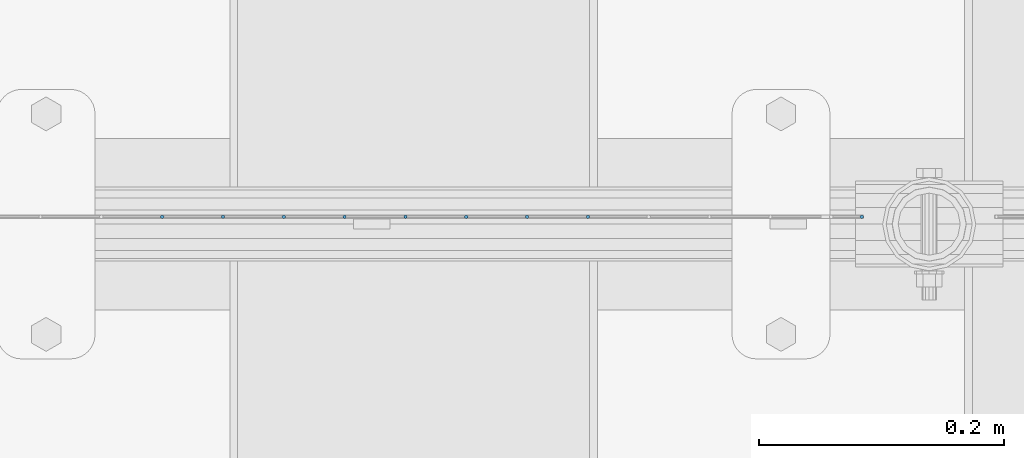
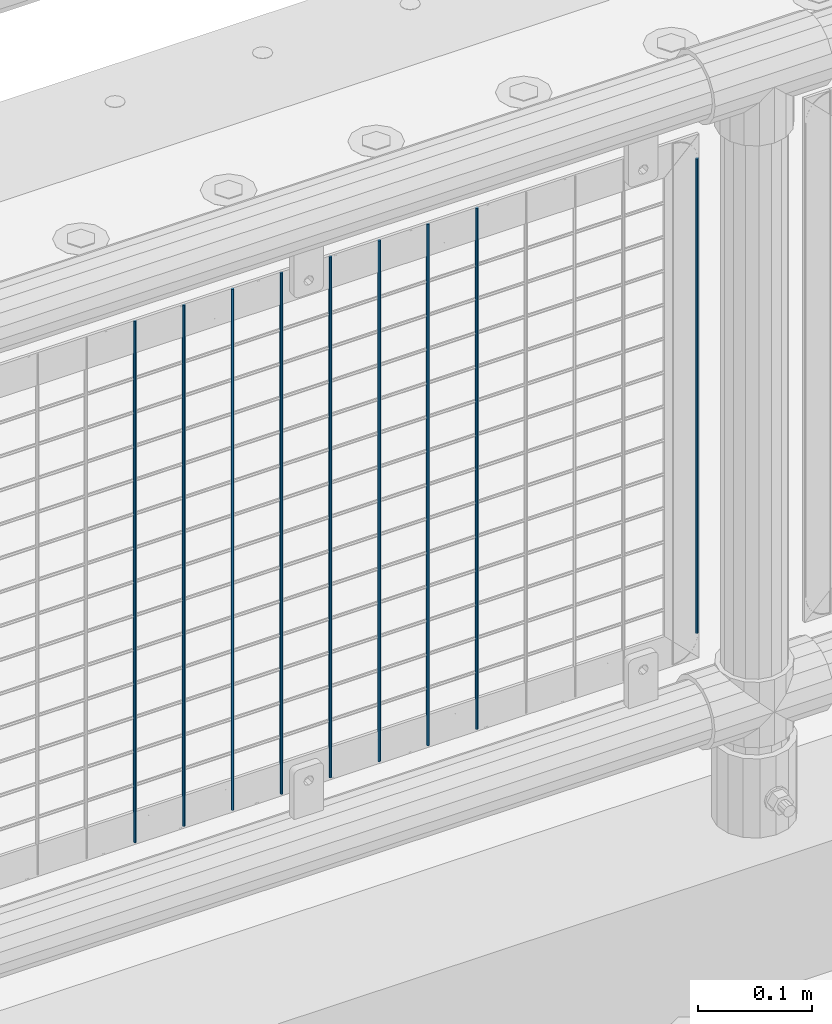
# One storey, part 71 of 208: 9 columns.
"""IFC2X3 building model written with IfcOpenShell, lengths in millimetres."""

import ifcopenshell
import ifcopenshell.guid

model = None  # the IFC model being written
_history = None  # IfcOwnerHistory: only IFC2X3 demands one
_inside = {}  # id of a spatial element -> (the spatial element, [elements in it])
_under = {}  # id of a project, library or spatial element -> (it, [spatial elements below it])
_declared = {}  # id of a project -> (the project, [libraries it declares])
_typed = {}  # id of a type object -> (the type object, [elements of that type])
_made_of = {}  # id of a material, layer set ... -> (it, [elements and type objects made of it])


def new_model(schema):
    """Start an empty IFC model of exactly this schema.

    Asked for "IFC4X3", IfcOpenShell would pick the latest addendum, in which some entities
    have other attributes; the version numbers below select the first issue.
    IFC2X3 requires an IfcOwnerHistory on every rooted entity: one is made here for all.
    """
    global model, _history
    if schema == "IFC4X3":
        model = ifcopenshell.file(schema_version=(4, 3, 0, 0))
    else:
        model = ifcopenshell.file(schema=schema)
    _inside.clear()
    _under.clear()
    _declared.clear()
    _typed.clear()
    _made_of.clear()
    _history = None
    if model.schema == "IFC2X3":
        org = make("IfcOrganization", Name="unknown")
        user = make(
            "IfcPersonAndOrganization",
            ThePerson=make("IfcPerson", FamilyName="unknown"),
            TheOrganization=org,
        )
        app = make(
            "IfcApplication",
            ApplicationDeveloper=org,
            Version="unknown",
            ApplicationFullName="unknown",
            ApplicationIdentifier="unknown",
        )
        _history = make(
            "IfcOwnerHistory",
            OwningUser=user,
            OwningApplication=app,
            ChangeAction="ADDED",
            CreationDate=0,
        )
    return model


def make(cls, **values):
    """One entity of the class cls with the attributes given. An attribute that is None is left unset."""
    return model.create_entity(
        cls, **{name: value for name, value in values.items() if value is not None}
    )


def rooted(cls, **values):
    """An entity with a GlobalId (a new one), such as an element, a storey or a relation."""
    return make(cls, GlobalId=ifcopenshell.guid.new(), OwnerHistory=_history, **values)


def si_unit(unit_type, name, prefix=None):
    """IfcSIUnit, for example si_unit("LENGTHUNIT", "METRE", prefix="MILLI")."""
    return make("IfcSIUnit", UnitType=unit_type, Prefix=prefix, Name=name)


def assignment(units):
    """IfcUnitAssignment: the units of a project."""
    return None if units is None else make("IfcUnitAssignment", Units=units)


def point(xyz):
    """IfcCartesianPoint."""
    return None if xyz is None else make("IfcCartesianPoint", Coordinates=xyz)


def direction(xyz):
    """IfcDirection."""
    return None if xyz is None else make("IfcDirection", DirectionRatios=xyz)


def frame(location, z_axis=None, x_axis=None):
    """IfcAxis2Placement3D, a coordinate frame: its origin and axes. An axis left out is left unset."""
    return make(
        "IfcAxis2Placement3D",
        Location=point(location),
        Axis=direction(z_axis),
        RefDirection=direction(x_axis),
    )


def origin_with_axes():
    """The frame at (0, 0, 0) with the z axis (0, 0, 1) and the x axis (1, 0, 0) written out."""
    return frame((0.0, 0.0, 0.0), z_axis=(0.0, 0.0, 1.0), x_axis=(1.0, 0.0, 0.0))


def place(relative_to, where):
    """IfcLocalPlacement: puts the frame where relative to a parent placement (None: the world)."""
    return make(
        "IfcLocalPlacement", PlacementRelTo=relative_to, RelativePlacement=where
    )


def context(
    kind, dimensions, precision=None, world=None, true_north=None, identifier=None
):
    """IfcGeometricRepresentationContext, for example the 3D "Model" context."""
    return make(
        "IfcGeometricRepresentationContext",
        ContextIdentifier=identifier,
        ContextType=kind,
        CoordinateSpaceDimension=dimensions,
        Precision=precision,
        WorldCoordinateSystem=world,
        TrueNorth=true_north,
    )


def subcontext(parent, identifier, kind, view, scale=None):
    """IfcGeometricRepresentationSubContext, for example "Body" below "Model"."""
    return make(
        "IfcGeometricRepresentationSubContext",
        ContextIdentifier=identifier,
        ContextType=kind,
        ParentContext=parent,
        TargetScale=scale,
        TargetView=view,
    )


def project(units=None, contexts=None):
    """IfcProject with its units and contexts."""
    return rooted(
        "IfcProject",
        Name="project",
        RepresentationContexts=contexts,
        UnitsInContext=assignment(units),
    )


def spatial(cls, under=None, at=None, **own):
    """A site, building, storey or space (cls), placed at a placement, below another one or the project."""
    s = rooted(cls, ObjectPlacement=at, **own)
    if under is not None:
        _under.setdefault(under.id(), (under, []))[1].append(s)
    return s


def faces_of(points, faces, orient=None, outer=None):
    """IfcFace entities. A face is a list of loops; a loop is a list of indices into points, from 0.

    orient and outer hold one flag for each loop. By default every Orientation is true, the
    first loop of a face is its IfcFaceOuterBound and the others are IfcFaceBound.
    """
    made = []
    for i, loops in enumerate(faces):
        bounds = []
        for j, loop in enumerate(loops):
            is_outer = j == 0 if outer is None else outer[i][j]
            bounds.append(
                make(
                    "IfcFaceOuterBound" if is_outer else "IfcFaceBound",
                    Bound=make("IfcPolyLoop", Polygon=[points[k] for k in loop]),
                    Orientation=True if orient is None else orient[i][j],
                )
            )
        made.append(make("IfcFace", Bounds=bounds))
    return made


def faceted_brep(points, faces, orient=None, outer=None, voids=None):
    """IfcFacetedBrep: a solid bounded by flat faces; with voids (closed shells), ...WithVoids."""
    shared = [point(p) for p in points]
    hull = make("IfcClosedShell", CfsFaces=faces_of(shared, faces, orient, outer))
    if voids is None:
        return make("IfcFacetedBrep", Outer=hull)
    return make(
        "IfcFacetedBrepWithVoids",
        Outer=hull,
        Voids=[
            make(cls, CfsFaces=faces_of(shared, fs, o, b)) for cls, fs, o, b in voids
        ],
    )


def shape(context_of_items, identifier, shape_type, items):
    """IfcShapeRepresentation: the items that make up one representation, for example the "Body"."""
    return make(
        "IfcShapeRepresentation",
        ContextOfItems=context_of_items,
        RepresentationIdentifier=identifier,
        RepresentationType=shape_type,
        Items=items,
    )


def material(Name=None, Category=None):
    """IfcMaterial."""
    return make("IfcMaterial", Name=Name, Category=Category)


def made_of(thing, what):
    """Note that an element or type object is made of a material, layer set ...; save() writes the relation."""
    if what is not None:
        _made_of.setdefault(what.id(), (what, []))[1].append(thing)
    return thing


def type_object(cls, material=None, **own):
    """A type object (cls), such as IfcWallType, which elements share."""
    return made_of(rooted(cls, **own), material)


def element(
    cls,
    number,
    at=None,
    inside=None,
    cuts=None,
    type_object=None,
    material=None,
    context=None,
    identifier="Body",
    shape_type=None,
    held_by="IfcProductDefinitionShape",
    body=None,
    shapes=None,
    **own,
):
    """One element of the class cls, such as IfcWall. Its Tag is "e" and its number.

    at: its placement. inside: the storey or other place that contains it. cuts: it is an
    opening in that element (IfcRelVoidsElement). A single representation is given by context,
    identifier, shape_type and body (its items); several are given by shapes. held_by: the class
    of the entity that holds the representations. save() writes the other relations.
    """
    e = rooted(cls, Tag="e%d" % number, ObjectPlacement=at, **own)
    if body is not None:
        shapes = [shape(context, identifier, shape_type, body)]
    if shapes is not None:
        e.Representation = make(held_by, Representations=shapes)
    if inside is not None:
        _inside.setdefault(inside.id(), (inside, []))[1].append(e)
    if cuts is not None:
        rooted(
            "IfcRelVoidsElement", RelatingBuildingElement=cuts, RelatedOpeningElement=e
        )
    if type_object is not None:
        _typed.setdefault(type_object.id(), (type_object, []))[1].append(e)
    return made_of(e, material)


def aggregate(whole, parts):
    """IfcRelAggregates: a whole, such as a stair, and the parts it consists of."""
    return rooted("IfcRelAggregates", RelatingObject=whole, RelatedObjects=parts)


def save(model, path):
    """Write the relations noted so far, then the file.

    IfcRelAggregates (storeys below a building ...), IfcRelContainedInSpatialStructure (elements
    in a storey), IfcRelDefinesByType, IfcRelAssociatesMaterial and IfcRelDeclares: one each for
    every whole, place, type object, material and project.
    """
    for whole, parts in _under.values():
        aggregate(whole, parts)
    for where, things in _inside.values():
        rooted(
            "IfcRelContainedInSpatialStructure",
            RelatedElements=things,
            RelatingStructure=where,
        )
    for kind, things in _typed.values():
        rooted("IfcRelDefinesByType", RelatedObjects=things, RelatingType=kind)
    for what, things in _made_of.values():
        rooted("IfcRelAssociatesMaterial", RelatedObjects=things, RelatingMaterial=what)
    for by, libraries in _declared.values():
        rooted("IfcRelDeclares", RelatingContext=by, RelatedDefinitions=libraries)
    model.write(path)


model = new_model("IFC2X3")

# Units and contexts
model_context = context("Model", 3, precision=1e-05, world=origin_with_axes())
body_context = subcontext(model_context, "Body", "Model", "MODEL_VIEW")
ifc_project = project(units=[si_unit("LENGTHUNIT", "METRE", prefix="MILLI"), si_unit("AREAUNIT", "SQUARE_METRE"), si_unit("VOLUMEUNIT", "CUBIC_METRE"), si_unit("MASSUNIT", "GRAM", prefix="KILO"), si_unit("TIMEUNIT", "SECOND"), si_unit("PLANEANGLEUNIT", "RADIAN"), si_unit("SOLIDANGLEUNIT", "STERADIAN"), si_unit("THERMODYNAMICTEMPERATUREUNIT", "DEGREE_CELSIUS"), si_unit("LUMINOUSINTENSITYUNIT", "LUMEN")], contexts=[model_context])

# Site, building, storey
site_placement = place(None, origin_with_axes())
site = spatial("IfcSite", under=ifc_project, at=site_placement, CompositionType="ELEMENT")
building_placement = place(site_placement, origin_with_axes())
building = spatial("IfcBuilding", under=site, at=building_placement, Name="Standard", CompositionType="ELEMENT")
storey_placement = place(building_placement, origin_with_axes())
storey = spatial("IfcBuildingStorey", under=building, at=storey_placement, Name="Undefined", CompositionType="ELEMENT", Elevation=0.0)

# Columns
ifc_material = material(Name="Misc_Undefined")
column_type = type_object("IfcColumnType", Name="D3", PredefinedType="NOTDEFINED")
for number, where, z_axis, x_axis in (
    (1, (-34107.625, 4670.50000000001, 353.020000000002), (-1.0, 0.0, 0.0), (0.0, 0.0, 1.0)),
    (2, (-34157.28, 4670.50000000001, 353.020000000002), (-1.0, 0.0, 0.0), (0.0, 0.0, 1.0)),
    (3, (-34206.935, 4670.50000000001, 353.020000000002), (-1.0, 0.0, 0.0), (0.0, 0.0, 1.0)),
    (4, (-34256.59, 4670.50000000001, 353.020000000002), (-1.0, 0.0, 0.0), (0.0, 0.0, 1.0)),
    (5, (-34306.245, 4670.50000000001, 353.020000000002), (-1.0, 0.0, 0.0), (0.0, 0.0, 1.0)),
    (6, (-34355.9, 4670.50000000001, 353.020000000002), (-1.0, 0.0, 0.0), (0.0, 0.0, 1.0)),
    (7, (-34405.555, 4670.50000000001, 353.020000000002), (-1.0, 0.0, 0.0), (0.0, 0.0, 1.0)),
    (8, (-34455.21, 4670.5, 353.020000000002), (-1.0, 0.0, 0.0), (0.0, 0.0, 1.0)),
):
    element("IfcColumn", number, at=place(storey_placement, frame(where, z_axis=z_axis, x_axis=x_axis)), inside=storey, type_object=column_type, material=ifc_material, ObjectType="D3", context=body_context, shape_type="Brep", body=[
        faceted_brep([(0.0, -1.49999999999909, 3.63797880709171e-12), (-7.27595761418343e-12, -0.749999999999091, -1.29903810567669), (560.0, -0.75, -1.29903810567703), (560.0, -1.5, 0.0), (-3.63797880709171e-12, 0.750000000000909, -1.29903810567669), (560.0, 0.75, -1.29903810567703), (0.0, 1.50000000000182, 3.63797880709171e-12), (560.0, 1.5, 0.0), (-3.63797880709171e-12, 0.750000000000909, 1.29903810567669), (560.0, 0.75, 1.29903810567703), (-7.27595761418343e-12, -0.749999999999091, 1.29903810567669), (560.0, -0.75, 1.29903810567703)], [[[0, 1, 2, 3]], [[1, 4, 5, 2]], [[4, 6, 7, 5]], [[6, 8, 9, 7]], [[8, 10, 11, 9]], [[10, 0, 3, 11]], [[5, 7, 9, 11, 3, 2]], [[10, 8, 6, 4, 1, 0]]]),
    ])
column_placement = place(storey_placement, frame((-33884.0, 4670.5, 378.020000000002), z_axis=(-1.0, 0.0, 0.0), x_axis=(0.0, 0.0, 1.0)))
element("IfcColumn", 9, at=column_placement, inside=storey, type_object=column_type, material=ifc_material, ObjectType="D3", context=body_context, shape_type="Brep", body=[
    faceted_brep([(0.0, -1.49999999999909, 3.63797880709171e-12), (-7.27595761418343e-12, -0.749999999999091, -1.29903810567669), (510.0, -0.75, -1.29903810567703), (510.0, -1.5, 0.0), (-3.63797880709171e-12, 0.750000000000909, -1.29903810567669), (510.0, 0.75, -1.29903810567703), (0.0, 1.50000000000182, 3.63797880709171e-12), (510.0, 1.5, 0.0), (-3.63797880709171e-12, 0.750000000000909, 1.29903810567669), (510.0, 0.75, 1.29903810567703), (-7.27595761418343e-12, -0.749999999999091, 1.29903810567669), (510.0, -0.75, 1.29903810567703)], [[[0, 1, 2, 3]], [[1, 4, 5, 2]], [[4, 6, 7, 5]], [[6, 8, 9, 7]], [[8, 10, 11, 9]], [[10, 0, 3, 11]], [[5, 7, 9, 11, 3, 2]], [[10, 8, 6, 4, 1, 0]]]),
])

save(model, "model.ifc")
